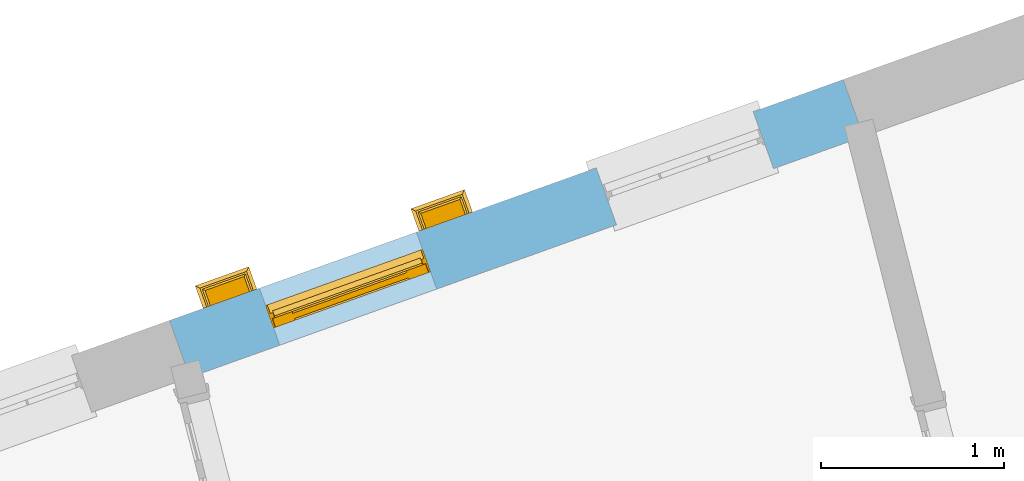
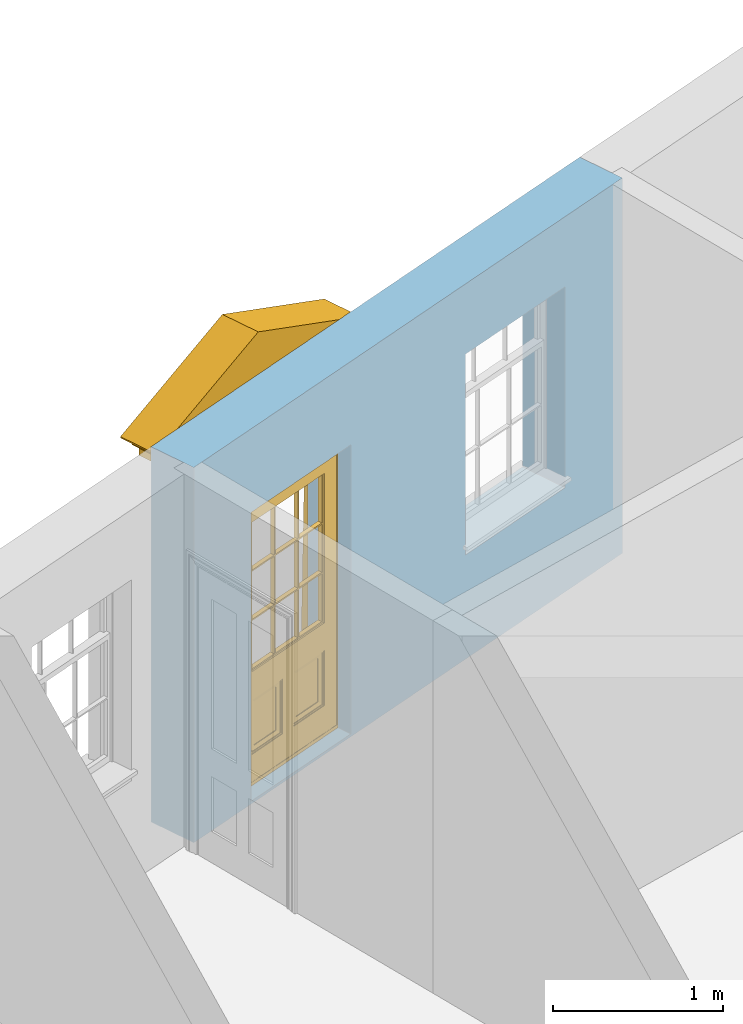
# One storey, part 12 of 15: 1 door, 2 openings, plus 1 element that does not belong to this part.
"""IFC2X3 building model written with IfcOpenShell, lengths in metres."""

from ifc_helpers import new_model, si_unit, frame, origin, place, context, subcontext, project, spatial, polyline, outline, extrude, faceted_brep, material, layer, layer_set, layer_usage, element, fill, save


model = new_model("IFC2X3")

# Units and contexts
model_context = context("Model", 3, world=origin())
body_context = subcontext(model_context, "Body", "Model", "MODEL_VIEW")
ifc_project = project(units=[si_unit("PLANEANGLEUNIT", "RADIAN"), si_unit("MASSUNIT", "GRAM", prefix="KILO"), si_unit("FORCEUNIT", "NEWTON", prefix="KILO"), si_unit("LENGTHUNIT", "METRE")], contexts=[model_context])

# Site, building, storey
site_placement = place(None, origin())
site = spatial("IfcSite", under=ifc_project, at=site_placement, CompositionType="ELEMENT")
building_placement = place(None, origin())
building = spatial("IfcBuilding", under=site, at=building_placement, Name="Building plot-13", CompositionType="ELEMENT")
storey_placement = place(None, frame((0.0, 0.0, 4.0)))
storey = spatial("IfcBuildingStorey", under=building, at=storey_placement, Name="Floor 0", CompositionType="ELEMENT", Elevation=4.0)

# Wall, openings, door
ifc_material = material(Name="Masonry")
ifc_layer = layer(ifc_material, 0.33, ventilated=False)
ifc_layer_set = layer_set([ifc_layer], Name="My Wall")
ifc_layer_usage = layer_usage(ifc_layer_set, "AXIS2", "NEGATIVE", 0.08)
wall_placement = place(storey_placement, origin())
wall = element("IfcWallStandardCase", 1, at=wall_placement, inside=storey, material=ifc_layer_usage, Name="exterior", context=body_context, shape_type="SweptSolid", body=[
    extrude(outline(polyline([(75.765136209946, 51.0653233722537), (75.6540271002417, 51.3760559996695), (71.9792289491637, 50.0620531725284), (72.090338058868, 49.7513205451126), (75.765136209946, 51.0653233722537)])), origin(), (0.0, 0.0, 1.0), 2.7),
])
opening_1_placement = place(storey_placement, frame((0.0, 0.0, 0.75)))
element("IfcOpeningElement", 2, at=opening_1_placement, cuts=wall, Name="Opening", ObjectType="Opening", context=body_context, shape_type="SweptSolid", body=[
    extrude(outline(polyline([(75.163761942697, 51.2007511865675), (74.3068931822474, 50.894359399201), (74.4180022919517, 50.5836267717852), (75.2748710524013, 50.8900185591517), (75.163761942697, 51.2007511865675)])), origin(), (0.0, 0.0, 1.0), 1.445),
])
opening_2_placement = place(storey_placement, frame((0.0, 0.0, 0.0199999999999996)))
opening_2 = element("IfcOpeningElement", 3, at=opening_2_placement, cuts=wall, Name="Opening", ObjectType="Opening", context=body_context, shape_type="SweptSolid", body=[
    extrude(outline(polyline([(73.326362867158, 50.5437497729969), (72.4694941067084, 50.2373579856305), (72.5806032164127, 49.9266253582147), (73.4374719768623, 50.2330171455811), (73.326362867158, 50.5437497729969)])), origin(), (0.0, 0.0, 1.0), 2.08),
])
door_placement = place(storey_placement, frame((73.4105364351158, 50.3083462673789, 0.0199999999999996), z_axis=(0.0, 0.0, 1.0), x_axis=(-0.856868760449572, -0.306391787366429, 0.0)))
door = element("IfcDoor", 4, at=door_placement, inside=storey, Name="house entrance", OverallHeight=2.08, OverallWidth=0.91, context=body_context, shape_type="Brep", held_by="IfcProductRepresentation", body=[
    faceted_brep([(-0.305, -0.25, 2.43), (-0.335, -0.25, 2.45), (1.245, -0.25, 2.45), (1.215, -0.25, 2.43), (-0.315, -0.25, 2.43), (-0.335, -0.25, 2.46), (1.245, -0.25, 2.46), (1.225, -0.25, 2.43), (-0.295, -0.25, 2.42), (1.205, -0.25, 2.42), (-0.315, -0.37, 2.43), (-0.305, -0.36, 2.43), (-0.335, -0.39, 2.45), (-0.335, -0.39, 2.46), (-0.395, -0.25, 2.52), (1.305, -0.25, 2.52), (1.245, -0.39, 2.46), (1.245, -0.39, 2.45), (1.225, -0.37, 2.43), (1.215, -0.36, 2.43), (-0.305, -0.25, 2.42), (1.215, -0.25, 2.42), (-0.285, -0.25, 2.41), (1.195, -0.25, 2.41), (-0.305, -0.36, 2.42), (-0.395, -0.45, 2.46), (-0.395, -0.25, 2.46), (-0.405, -0.25, 2.53), (1.315, -0.25, 2.53), (1.305, -0.25, 2.46), (1.305, -0.45, 2.46), (1.215, -0.36, 2.42), (-0.295, -0.35, 2.42), (1.205, -0.35, 2.42), (-0.285, -0.34, 2.41), (1.195, -0.34, 2.41), (-0.275, -0.25, 2.4), (1.185, -0.25, 2.4), (-0.395, -0.45, 2.52), (-0.405, -0.25, 2.52), (-0.415, -0.25, 2.54), (1.325, -0.25, 2.54), (1.315, -0.25, 2.52), (1.305, -0.45, 2.52), (-0.285, -0.25, 2.4), (-0.285, -0.34, 2.4), (1.195, -0.34, 2.4), (1.195, -0.25, 2.4), (-0.275, -0.25, 2.21), (1.185, -0.25, 2.21), (-0.405, -0.46, 2.52), (-0.405, -0.46, 2.53), (-0.415, -0.47, 2.54), (-0.425, -0.25, 2.55), (1.335, -0.25, 2.55), (1.325, -0.47, 2.54), (1.315, -0.46, 2.53), (1.315, -0.46, 2.52), (-0.275, -0.33, 2.4), (1.185, -0.33, 2.4), (-0.275, -0.33, 2.21), (1.185, -0.33, 2.21), (-0.275, -0.25, 2.2), (1.185, -0.25, 2.2), (-0.425, -0.48, 2.54), (-0.425, -0.25, 2.54), (-0.445, -0.25, 2.581), (1.355, -0.25, 2.581), (1.335, -0.25, 2.54), (1.335, -0.48, 2.54), (-0.285, -0.34, 2.21), (-0.285, -0.25, 2.21), (1.195, -0.34, 2.21), (1.195, -0.25, 2.21), (-0.285, -0.25, 2.2), (1.195, -0.25, 2.2), (-0.015, -0.25, 2.11), (0.925, -0.25, 2.11), (-0.425, -0.48, 2.55), (-0.435, -0.25, 2.556), (-0.473, -0.25, 2.591), (1.383, -0.25, 2.591), (1.345, -0.25, 2.556), (1.335, -0.48, 2.55), (-0.285, -0.34, 2.2), (1.195, -0.34, 2.2), (-0.275, -0.33, 2.2), (1.185, -0.33, 2.2), (-0.275, -0.25, 2.11), (1.185, -0.25, 2.11), (-0.015, -0.33, 2.11), (0.925, -0.33, 2.11), (-0.435, -0.49, 2.556), (-0.400858, -0.48, 2.55), (1.310858, -0.48, 2.55), (-0.445, -0.5, 2.581), (-0.473, -0.528, 2.591), (-0.473, -0.25, 2.601), (1.383, -0.25, 2.601), (1.383, -0.528, 2.591), (1.355, -0.5, 2.581), (1.345, -0.49, 2.556), (-0.275, -0.33, 2.11), (1.185, -0.33, 2.11), (-0.025, -0.25, 2.1), (-0.315, -0.25, 2.1), (1.225, -0.25, 2.1), (0.935, -0.25, 2.1), (-0.015, -0.38, 2.1), (0.925, -0.25, 2.1), (0.455, -0.48, 2.914508), (0.455, -0.49, 2.92465), (0.455, -0.48, 2.904508), (1.236538, -0.46, 2.552499), (-0.326538, -0.46, 2.552499), (0.455, -0.5, 2.953792), (0.455, -0.528, 2.975389), (-0.473, -0.528, 2.601), (0.455, -0.25, 2.985389), (1.383, -0.528, 2.601), (-0.325, -0.25, 2.11), (-0.325, -0.38, 2.11), (1.235, -0.38, 2.11), (1.235, -0.25, 2.11), (-0.015, -0.25, 2.1), (-0.035, -0.25, 2.07), (-0.305, -0.25, 2.07), (-0.325, -0.25, 2.1), (1.235, -0.25, 2.1), (0.945, -0.25, 2.07), (1.215, -0.25, 2.07), (-0.015, -0.38, 2.11), (0.925, -0.38, 2.11), (-0.38784, -0.47, 2.55125), (0.455, -0.47, 2.900365), (1.26068, -0.46, 2.552499), (1.29784, -0.47, 2.55125), (1.066733, -0.45, 2.553749), (-0.156733, -0.45, 2.553749), (-0.35068, -0.46, 2.552499), (0.455, -0.528, 2.985389), (-0.325, -0.38, 2.1), (1.235, -0.38, 2.1), (-0.025, -0.37, 2.1), (-0.025, -0.25, 2.07), (-0.305, -0.25, 2.06), (-0.035, -0.25, 2.06), (-0.315, -0.25, 2.07), (-0.315, -0.37, 2.1), (1.225, -0.37, 2.1), (0.935, -0.25, 2.07), (1.225, -0.25, 2.07), (1.215, -0.25, 2.06), (0.945, -0.25, 2.06), (0.935, -0.37, 2.1), (0.925, -0.38, 2.1), (0.455, -0.46, 2.886223), (0.455, -0.46, 2.876222), (1.022495, -0.39, 2.56125), (-0.112495, -0.39, 2.56125), (-0.31352, -0.45, 2.553749), (1.22352, -0.45, 2.553749), (-0.025, -0.37, 2.07), (-0.035, -0.36, 2.07), (-0.305, -0.36, 2.06), (-0.305, -0.36, 2.07), (-0.035, -0.36, 2.06), (-0.285, -0.25, 2.04), (-0.055, -0.25, 2.04), (-0.315, -0.37, 2.07), (1.225, -0.37, 2.07), (0.945, -0.36, 2.07), (0.935, -0.37, 2.07), (1.215, -0.36, 2.07), (1.215, -0.36, 2.06), (1.195, -0.25, 2.04), (0.965, -0.25, 2.04), (0.945, -0.36, 2.06), (0.455, -0.45, 2.872082), (1.048626, -0.39, 2.56125), (0.964197, -0.37, 2.563749), (-0.054197, -0.37, 2.563749), (-0.138626, -0.39, 2.56125), (0.455, -0.45, 2.807137), (-0.285, -0.34, 2.04), (-0.055, -0.34, 2.04), (-0.065, -0.25, 2.03), (-0.275, -0.25, 2.03), (1.195, -0.34, 2.04), (1.185, -0.25, 2.03), (0.975, -0.25, 2.03), (0.965, -0.34, 2.04), (0.455, -0.39, 2.796314), (0.455, -0.39, 2.807137), (0.455, -0.37, 2.774666), (0.935048, -0.36, 2.565), (-0.025048, -0.36, 2.565), (-0.285, -0.25, 2.03), (-0.285, -0.34, 2.03), (-0.055, -0.25, 2.03), (-0.055, -0.34, 2.03), (-0.275, -0.25, 1.94), (-0.065, -0.25, 1.94), (1.195, -0.25, 2.03), (1.195, -0.34, 2.03), (1.185, -0.25, 1.94), (0.975, -0.25, 1.94), (0.965, -0.25, 2.03), (0.965, -0.34, 2.03), (0.455, -0.36, 2.774666), (0.961179, -0.36, 2.565), (0.87675, -0.34, 2.567501), (0.03325, -0.34, 2.567501), (-0.051179, -0.36, 2.565), (-0.275, -0.33, 2.03), (-0.065, -0.33, 2.03), (-0.275, -0.33, 1.94), (-0.065, -0.33, 1.94), (-0.275, -0.25, 1.93), (-0.065, -0.25, 1.93), (1.185, -0.33, 2.03), (1.185, -0.33, 1.94), (1.185, -0.25, 1.93), (0.975, -0.25, 1.93), (0.975, -0.33, 1.94), (0.975, -0.33, 2.03), (0.455, -0.36, 2.763843), (0.902881, -0.34, 2.567501), (0.93203, -0.35, 2.566251), (0.036268, -0.33, 2.568751), (0.873732, -0.33, 2.568751), (-0.02203, -0.35, 2.566251), (0.007119, -0.34, 2.567501), (-0.285, -0.25, 1.94), (-0.285, -0.34, 1.94), (-0.055, -0.34, 1.94), (-0.055, -0.25, 1.94), (-0.285, -0.25, 1.93), (-0.055, -0.25, 1.93), (-0.295, -0.25, 0.13), (-0.045, -0.25, 0.13), (1.195, -0.34, 1.94), (1.195, -0.25, 1.94), (1.195, -0.25, 1.93), (1.205, -0.25, 0.13), (0.955, -0.25, 0.13), (0.965, -0.25, 1.94), (0.965, -0.25, 1.93), (0.965, -0.34, 1.94), (0.455, -0.35, 2.763843), (0.455, -0.34, 2.742194), (0.455, -0.34, 2.753017), (0.455, -0.33, 2.742194), (-0.285, -0.34, 1.93), (-0.055, -0.34, 1.93), (-0.275, -0.33, 1.93), (-0.065, -0.33, 1.93), (-0.295, -0.35, 0.13), (-0.045, -0.35, 0.13), (-0.305, -0.25, 0.12), (-0.035, -0.25, 0.12), (1.195, -0.34, 1.93), (1.185, -0.33, 1.93), (1.205, -0.35, 0.13), (1.215, -0.25, 0.12), (0.945, -0.25, 0.12), (0.955, -0.35, 0.13), (0.975, -0.33, 1.93), (0.965, -0.34, 1.93), (-0.305, -0.25, 0.13), (-0.305, -0.36, 0.13), (-0.035, -0.25, 0.13), (-0.035, -0.36, 0.13), (-0.325, -0.25, 0.1), (-0.015, -0.25, 0.1), (1.215, -0.36, 0.13), (1.215, -0.25, 0.13), (1.235, -0.25, 0.1), (0.925, -0.25, 0.1), (0.945, -0.25, 0.13), (0.945, -0.36, 0.13), (-0.305, -0.36, 0.12), (-0.035, -0.36, 0.12), (-0.325, -0.38, 0.1), (-0.015, -0.38, 0.1), (-0.325, -0.25, 0.08), (-0.015, -0.25, 0.08), (1.215, -0.36, 0.12), (1.235, -0.38, 0.1), (1.235, -0.25, 0.08), (0.925, -0.25, 0.08), (0.925, -0.38, 0.1), (0.945, -0.36, 0.12), (-0.325, -0.38, 0.08), (-0.015, -0.38, 0.08), (-0.315, -0.25, 0.07), (-0.025, -0.25, 0.07), (1.235, -0.38, 0.08), (1.225, -0.25, 0.07), (0.935, -0.25, 0.07), (0.925, -0.38, 0.08), (-0.315, -0.37, 0.07), (-0.025, -0.37, 0.07), (-0.015, -0.25, 0.0), (-0.325, -0.25, 0.0), (1.225, -0.37, 0.07), (1.235, -0.25, 0.0), (0.925, -0.25, 0.0), (0.935, -0.37, 0.07), (-0.325, -0.25, 0.07), (-0.325, -0.38, 0.07), (-0.015, -0.38, 0.07), (-0.015, -0.25, 0.07), (-0.015, -0.38, 0.0), (-0.325, -0.38, 0.0), (1.235, -0.38, 0.07), (1.235, -0.25, 0.07), (1.235, -0.38, 0.0), (0.925, -0.38, 0.0), (0.925, -0.25, 0.07), (0.925, -0.38, 0.07), (0.885, -0.072, 0.025), (0.025, -0.072, 0.025), (0.025, -0.1, 0.025), (0.885, -0.1, 0.025), (0.9, -0.02, 0.025), (0.01, -0.02, 0.025), (0.9, -0.072, 0.025), (0.91, -0.02, 0.0), (0.0, -0.02, 0.0), (0.01, -0.072, 0.025), (0.9, -0.072, 2.07), (0.9, -0.02, 2.07), (0.885, -0.072, 2.055), (0.91, -0.02, 2.08), (0.01, -0.02, 2.07), (0.0, -0.02, 2.08), (0.01, -0.072, 2.07), (0.025, -0.072, 2.055), (0.0, -0.15, 0.0), (0.0, -0.15, 2.08), (0.91, -0.15, 0.0), (0.01, -0.15, 0.025), (0.01, -0.15, 2.07), (0.9, -0.15, 0.025), (0.91, -0.15, 2.08), (0.01, -0.1, 0.025), (0.01, -0.1, 2.065), (0.9, -0.15, 2.07), (0.025, -0.1, 2.055), (0.9, -0.1, 2.065), (0.9, -0.1, 0.025), (0.885, -0.1, 2.055), (0.898, -0.07, 2.068), (0.898, -0.02, 2.068), (0.012, -0.02, 2.068), (0.012, -0.07, 2.068), (0.898, -0.07, 0.075), (0.898, -0.02, 0.027), (0.012, -0.02, 0.027), (0.012, -0.07, 0.075), (0.898, -0.07, 0.027), (0.012, -0.07, 0.027), (0.883, -0.07, 0.027), (0.883, -0.07, 0.075), (0.027, -0.07, 0.027), (0.027, -0.07, 0.075), (0.883, -0.08, 0.075), (0.883, -0.11, 0.045), (0.027, -0.11, 0.045), (0.027, -0.08, 0.075), (0.027, -0.11, 0.027), (0.883, -0.11, 0.027), (0.745, -0.05, 0.265), (0.545, -0.05, 0.265), (0.545, -0.055, 0.265), (0.745, -0.055, 0.265), (0.745, -0.05, 0.58), (0.545, -0.05, 0.58), (0.545, -0.055, 0.58), (0.515, -0.06, 0.235), (0.775, -0.06, 0.235), (0.745, -0.055, 0.58), (0.515, -0.06, 0.61), (0.515, -0.065, 0.235), (0.775, -0.065, 0.235), (0.775, -0.06, 0.61), (0.515, -0.065, 0.61), (0.785, -0.065, 0.225), (0.505, -0.065, 0.225), (0.775, -0.065, 0.61), (0.505, -0.065, 0.62), (0.785, -0.065, 0.62), (0.505, -0.07, 0.225), (0.785, -0.07, 0.225), (0.505, -0.07, 0.62), (0.785, -0.07, 0.62), (0.405, -0.07, 0.62), (0.405, -0.07, 0.225), (0.785, -0.07, 0.82), (0.125, -0.07, 0.82), (0.405, -0.065, 0.62), (0.405, -0.065, 0.225), (0.125, -0.07, 0.225), (0.785, -0.06, 0.82), (0.125, -0.06, 0.82), (0.125, -0.07, 0.62), (0.125, -0.065, 0.62), (0.395, -0.065, 0.61), (0.395, -0.065, 0.235), (0.125, -0.065, 0.225), (0.785, -0.07, 1.895), (0.558333, -0.06, 0.83), (0.351667, -0.06, 0.83), (0.125, -0.07, 1.895), (0.125, -0.06, 1.895), (0.785, -0.06, 1.895), (0.135, -0.065, 0.61), (0.395, -0.06, 0.61), (0.395, -0.06, 0.235), (0.135, -0.065, 0.235), (0.568333, -0.06, 0.83), (0.558333, -0.03, 0.83), (0.351667, -0.03, 0.83), (0.341667, -0.06, 0.83), (0.135, -0.06, 1.185), (0.135, -0.06, 1.53), (0.775, -0.06, 1.53), (0.775, -0.06, 1.185), (0.135, -0.06, 0.61), (0.365, -0.055, 0.58), (0.365, -0.055, 0.265), (0.135, -0.06, 0.235), (0.568333, -0.06, 1.175), (0.558333, -0.06, 1.175), (0.775, -0.06, 0.83), (0.558333, -0.03, 1.175), (0.785, -0.03, 0.82), (0.125, -0.03, 0.82), (0.351667, -0.03, 1.175), (0.351667, -0.06, 1.175), (0.341667, -0.06, 1.175), (0.135, -0.06, 0.83), (0.135, -0.06, 1.175), (0.135, -0.03, 1.185), (0.135, -0.03, 1.53), (0.135, -0.06, 1.54), (0.351667, -0.06, 1.885), (0.558333, -0.06, 1.885), (0.775, -0.03, 1.53), (0.775, -0.03, 1.185), (0.775, -0.06, 1.175), (0.775, -0.06, 1.54), (0.165, -0.055, 0.58), (0.365, -0.05, 0.58), (0.365, -0.05, 0.265), (0.165, -0.055, 0.265), (0.568333, -0.03, 0.83), (0.568333, -0.03, 1.175), (0.568333, -0.06, 1.185), (0.558333, -0.06, 1.185), (0.775, -0.03, 0.83), (0.785, -0.02, 0.82), (0.125, -0.02, 0.82), (0.341667, -0.03, 0.83), (0.341667, -0.03, 1.175), (0.351667, -0.06, 1.185), (0.341667, -0.06, 1.185), (0.135, -0.03, 0.83), (0.341667, -0.03, 1.185), (0.125, -0.03, 1.895), (0.341667, -0.03, 1.53), (0.341667, -0.06, 1.53), (0.135, -0.06, 1.885), (0.341667, -0.06, 1.54), (0.341667, -0.06, 1.885), (0.558333, -0.03, 1.885), (0.351667, -0.03, 1.885), (0.568333, -0.06, 1.885), (0.785, -0.03, 1.895), (0.568333, -0.03, 1.185), (0.568333, -0.06, 1.53), (0.568333, -0.03, 1.53), (0.568333, -0.06, 1.54), (0.775, -0.06, 1.885), (0.165, -0.05, 0.58), (0.165, -0.05, 0.265), (0.775, -0.03, 1.175), (0.558333, -0.06, 1.53), (0.351667, -0.03, 1.185), (0.558333, -0.03, 1.185), (0.505, -0.02, 0.62), (0.405, -0.02, 0.62), (0.125, -0.02, 1.895), (0.785, -0.02, 1.895), (0.351667, -0.06, 1.53), (0.135, -0.03, 1.175), (0.135, -0.03, 1.54), (0.341667, -0.03, 1.54), (0.135, -0.03, 1.885), (0.351667, -0.06, 1.54), (0.558333, -0.03, 1.54), (0.558333, -0.06, 1.54), (0.351667, -0.03, 1.54), (0.775, -0.03, 1.54), (0.568333, -0.03, 1.54), (0.775, -0.03, 1.885), (0.558333, -0.03, 1.53), (0.405, -0.02, 0.225), (0.505, -0.02, 0.225), (0.125, -0.02, 0.62), (0.785, -0.02, 0.62), (0.351667, -0.03, 1.53), (0.341667, -0.03, 1.885), (0.568333, -0.03, 1.885), (0.405, -0.025, 0.225), (0.405, -0.025, 0.62), (0.505, -0.025, 0.62), (0.505, -0.025, 0.225), (0.125, -0.025, 0.62), (0.785, -0.025, 0.62), (0.395, -0.025, 0.235), (0.395, -0.025, 0.61), (0.125, -0.02, 0.225), (0.125, -0.025, 0.225), (0.515, -0.025, 0.61), (0.515, -0.025, 0.235), (0.785, -0.02, 0.225), (0.785, -0.025, 0.225), (0.135, -0.025, 0.61), (0.775, -0.025, 0.61), (0.135, -0.025, 0.235), (0.395, -0.03, 0.235), (0.395, -0.03, 0.61), (0.515, -0.03, 0.61), (0.515, -0.03, 0.235), (0.775, -0.025, 0.235), (0.135, -0.03, 0.61), (0.775, -0.03, 0.61), (0.135, -0.03, 0.235), (0.365, -0.035, 0.265), (0.365, -0.035, 0.58), (0.545, -0.035, 0.58), (0.545, -0.035, 0.265), (0.775, -0.03, 0.235), (0.165, -0.035, 0.58), (0.745, -0.035, 0.58), (0.165, -0.035, 0.265), (0.365, -0.04, 0.58), (0.365, -0.04, 0.265), (0.545, -0.04, 0.58), (0.545, -0.04, 0.265), (0.745, -0.035, 0.265), (0.165, -0.04, 0.58), (0.745, -0.04, 0.58), (0.165, -0.04, 0.265), (0.745, -0.04, 0.265)], [[[0, 1, 2, 3]], [[0, 4, 1]], [[1, 5, 6, 2]], [[7, 3, 2]], [[8, 0, 3, 9]], [[10, 4, 0, 11]], [[12, 1, 4, 10]], [[1, 12, 13, 5]], [[5, 14, 15, 6]], [[6, 16, 17, 2]], [[7, 18, 19, 3]], [[2, 17, 18, 7]], [[8, 20, 0]], [[21, 9, 3]], [[22, 8, 9, 23]], [[11, 0, 20, 24]], [[10, 11, 19, 18]], [[12, 10, 18, 17]], [[25, 26, 5, 13]], [[13, 12, 17, 16]], [[5, 26, 14]], [[14, 27, 28, 15]], [[29, 6, 15]], [[29, 30, 16, 6]], [[3, 19, 31, 21]], [[24, 20, 8, 32]], [[21, 31, 33, 9]], [[32, 8, 22, 34]], [[9, 33, 35, 23]], [[36, 22, 23, 37]], [[11, 24, 31, 19]], [[38, 14, 26, 25]], [[25, 13, 16, 30]], [[14, 39, 27]], [[27, 40, 41, 28]], [[42, 15, 28]], [[15, 43, 30, 29]], [[24, 32, 33, 31]], [[34, 22, 44, 45]], [[32, 34, 35, 33]], [[23, 35, 46, 47]], [[36, 44, 22]], [[47, 37, 23]], [[48, 36, 37, 49]], [[50, 39, 14, 38]], [[38, 25, 30, 43]], [[51, 27, 39, 50]], [[52, 40, 27, 51]], [[40, 53, 54, 41]], [[41, 55, 56, 28]], [[42, 57, 43, 15]], [[28, 56, 57, 42]], [[45, 44, 36, 58]], [[34, 45, 46, 35]], [[47, 46, 59, 37]], [[60, 58, 36, 48]], [[59, 61, 49, 37]], [[62, 48, 49, 63]], [[50, 38, 43, 57]], [[51, 50, 57, 56]], [[64, 65, 40, 52]], [[52, 51, 56, 55]], [[40, 65, 53]], [[53, 66, 67, 54]], [[68, 41, 54]], [[68, 69, 55, 41]], [[45, 58, 59, 46]], [[58, 60, 61, 59]], [[70, 60, 48, 71]], [[61, 72, 73, 49]], [[71, 48, 62, 74]], [[49, 73, 75, 63]], [[76, 62, 63, 77]], [[78, 53, 65, 64]], [[64, 52, 55, 69]], [[53, 79, 66]], [[66, 80, 81, 67]], [[82, 54, 67]], [[54, 83, 69, 68]], [[60, 70, 72, 61]], [[84, 70, 71, 74]], [[72, 85, 75, 73]], [[86, 84, 74, 62]], [[85, 87, 63, 75]], [[76, 88, 62]], [[89, 77, 63]], [[90, 76, 77, 91]], [[92, 79, 53, 78]], [[78, 64, 93]], [[64, 69, 94, 93]], [[95, 66, 79, 92]], [[80, 66, 95, 96]], [[80, 97, 98, 81]], [[99, 100, 67, 81]], [[82, 101, 83, 54]], [[67, 100, 101, 82]], [[83, 94, 69]], [[70, 84, 85, 72]], [[84, 86, 87, 85]], [[102, 86, 62, 88]], [[87, 103, 89, 63]], [[88, 76, 104, 105]], [[77, 89, 106, 107]], [[76, 90, 108]], [[91, 77, 109]], [[86, 90, 91, 87]], [[78, 110, 111, 92]], [[110, 78, 93, 112]], [[93, 94, 113, 114]], [[92, 111, 115, 95]], [[95, 115, 116, 96]], [[117, 97, 80, 96]], [[118, 98, 97]], [[98, 119, 99, 81]], [[116, 115, 100, 99]], [[101, 111, 110, 83]], [[100, 115, 111, 101]], [[112, 94, 83, 110]], [[86, 102, 90]], [[102, 88, 120, 121]], [[103, 87, 91]], [[89, 103, 122, 123]], [[76, 124, 104]], [[104, 125, 126, 105]], [[120, 88, 105, 127]], [[89, 123, 128, 106]], [[129, 107, 106, 130]], [[109, 77, 107]], [[90, 131, 108]], [[108, 124, 76]], [[109, 132, 91]], [[112, 93, 133, 134]], [[135, 113, 94, 136]], [[137, 138, 114, 113]], [[133, 93, 114, 139]], [[116, 140, 117, 96]], [[118, 97, 117, 140]], [[98, 118, 140, 119]], [[140, 116, 99, 119]], [[134, 136, 94, 112]], [[121, 131, 90, 102]], [[120, 127, 141, 121]], [[132, 122, 103, 91]], [[128, 123, 122, 142]], [[104, 124, 108, 143]], [[104, 144, 125]], [[145, 126, 125, 146]], [[105, 126, 147]], [[127, 105, 148, 141]], [[106, 128, 142, 149]], [[129, 150, 107]], [[106, 151, 130]], [[130, 152, 153, 129]], [[109, 107, 154, 155]], [[108, 131, 121, 141]], [[109, 155, 132]], [[134, 133, 139, 156]], [[157, 113, 135, 156]], [[156, 135, 136, 134]], [[137, 158, 159, 138]], [[160, 114, 138]], [[161, 137, 113]], [[156, 139, 114, 157]], [[132, 155, 142, 122]], [[148, 143, 108, 141]], [[144, 104, 143, 162]], [[125, 144, 162, 163]], [[126, 145, 164, 165]], [[146, 125, 163, 166]], [[167, 145, 146, 168]], [[147, 126, 165, 169]], [[105, 147, 169, 148]], [[154, 149, 142, 155]], [[151, 106, 149, 170]], [[150, 129, 171, 172]], [[107, 150, 172, 154]], [[130, 151, 170, 173]], [[152, 130, 173, 174]], [[152, 175, 176, 153]], [[129, 153, 177, 171]], [[178, 161, 113, 157]], [[179, 158, 137]], [[158, 180, 181, 159]], [[182, 138, 159]], [[157, 114, 160, 178]], [[178, 160, 138, 183]], [[183, 137, 161, 178]], [[162, 143, 148, 169]], [[165, 163, 162, 169]], [[145, 167, 184, 164]], [[166, 163, 165, 164]], [[168, 146, 166, 185]], [[186, 187, 167, 168]], [[154, 172, 170, 149]], [[171, 173, 170, 172]], [[171, 177, 174, 173]], [[175, 152, 174, 188]], [[189, 190, 176, 175]], [[153, 176, 191, 177]], [[192, 158, 179, 193]], [[193, 179, 137, 183]], [[194, 180, 158, 192]], [[180, 195, 196, 181]], [[192, 159, 181, 194]], [[183, 138, 182, 193]], [[193, 182, 159, 192]], [[167, 197, 198, 184]], [[164, 184, 185, 166]], [[199, 168, 185, 200]], [[201, 187, 186, 202]], [[187, 197, 167]], [[168, 199, 186]], [[188, 174, 177, 191]], [[203, 175, 188, 204]], [[189, 205, 206, 190]], [[207, 176, 190]], [[203, 189, 175]], [[176, 207, 208, 191]], [[209, 210, 180, 194]], [[210, 195, 180]], [[195, 211, 212, 196]], [[213, 181, 196]], [[194, 181, 213, 209]], [[214, 198, 197, 187]], [[185, 184, 198, 200]], [[199, 200, 215, 186]], [[187, 201, 216, 214]], [[202, 186, 215, 217]], [[218, 201, 202, 219]], [[188, 191, 208, 204]], [[204, 220, 189, 203]], [[205, 189, 220, 221]], [[205, 222, 223, 206]], [[190, 206, 224, 225]], [[208, 207, 190, 225]], [[226, 195, 210, 209]], [[227, 211, 195, 228]], [[229, 212, 211, 230]], [[231, 196, 212, 232]], [[209, 213, 196, 226]], [[214, 215, 200, 198]], [[233, 234, 216, 201]], [[214, 216, 217, 215]], [[217, 235, 236, 202]], [[218, 237, 233, 201]], [[202, 236, 238, 219]], [[239, 218, 219, 240]], [[225, 220, 204, 208]], [[221, 220, 225, 224]], [[241, 242, 205, 221]], [[243, 222, 205, 242]], [[222, 244, 245, 223]], [[246, 206, 223, 247]], [[248, 224, 206, 246]], [[249, 228, 195, 226]], [[250, 211, 227, 251]], [[251, 227, 228, 249]], [[250, 212, 229, 252]], [[252, 230, 211, 250]], [[252, 229, 230]], [[226, 196, 231, 249]], [[251, 232, 212, 250]], [[249, 231, 232, 251]], [[237, 253, 234, 233]], [[217, 216, 234, 235]], [[238, 236, 235, 254]], [[255, 253, 237, 218]], [[238, 254, 256, 219]], [[218, 239, 257, 255]], [[240, 219, 256, 258]], [[259, 239, 240, 260]], [[221, 224, 248, 241]], [[261, 243, 242, 241]], [[261, 262, 222, 243]], [[262, 263, 244, 222]], [[244, 264, 265, 245]], [[223, 245, 266, 267]], [[268, 247, 223, 267]], [[246, 247, 268, 248]], [[253, 254, 235, 234]], [[255, 256, 254, 253]], [[239, 269, 270, 257]], [[255, 257, 258, 256]], [[271, 240, 258, 272]], [[259, 269, 239]], [[240, 271, 260]], [[273, 259, 260, 274]], [[268, 261, 241, 248]], [[267, 262, 261, 268]], [[263, 262, 267, 266]], [[263, 275, 276, 244]], [[276, 264, 244]], [[264, 277, 278, 265]], [[279, 245, 265]], [[245, 279, 280, 266]], [[269, 259, 281, 270]], [[272, 258, 257, 270]], [[260, 271, 272, 282]], [[259, 273, 283, 281]], [[274, 260, 282, 284]], [[285, 273, 274, 286]], [[275, 263, 266, 280]], [[264, 276, 275, 287]], [[277, 264, 287, 288]], [[277, 289, 290, 278]], [[265, 278, 291, 292]], [[279, 265, 292, 280]], [[282, 272, 270, 281]], [[285, 293, 283, 273]], [[284, 282, 281, 283]], [[286, 274, 284, 294]], [[295, 285, 286, 296]], [[280, 292, 287, 275]], [[292, 291, 288, 287]], [[297, 289, 277, 288]], [[289, 298, 299, 290]], [[278, 290, 300, 291]], [[285, 295, 301, 293]], [[294, 284, 283, 293]], [[296, 286, 294, 302]], [[303, 304, 295, 296]], [[291, 300, 297, 288]], [[298, 289, 297, 305]], [[306, 307, 299, 298]], [[290, 299, 308, 300]], [[309, 310, 301, 295]], [[293, 301, 302, 294]], [[302, 311, 312, 296]], [[313, 314, 304, 303]], [[304, 309, 295]], [[296, 312, 303]], [[305, 297, 300, 308]], [[315, 316, 298, 305]], [[317, 318, 307, 306]], [[319, 299, 307]], [[316, 306, 298]], [[320, 308, 299, 319]], [[309, 304, 314, 310]], [[302, 301, 310, 311]], [[303, 312, 311, 313]], [[310, 314, 313, 311]], [[305, 308, 320, 315]], [[306, 316, 315, 317]], [[317, 315, 320, 318]], [[319, 307, 318, 320]], [[321, 322, 323, 324]], [[322, 321, 325, 326]], [[327, 325, 321]], [[325, 328, 329, 326]], [[330, 322, 326]], [[331, 332, 325, 327]], [[327, 321, 333, 331]], [[332, 334, 328, 325]], [[335, 326, 329, 336]], [[337, 338, 322, 330]], [[326, 335, 337, 330]], [[332, 335, 336, 334]], [[331, 337, 335, 332]], [[336, 329, 339, 340]], [[341, 339, 329, 328]], [[339, 342, 343, 340]], [[339, 341, 344, 342]], [[345, 341, 328, 334]], [[346, 347, 343, 342]], [[348, 344, 341, 345]], [[342, 344, 324, 323]], [[323, 349, 347, 346]], [[346, 342, 323]], [[344, 348, 350, 351]], [[351, 324, 344]], [[338, 349, 323, 322]], [[351, 350, 352, 324]], [[333, 338, 337, 331]], [[333, 321, 324, 352]], [[340, 345, 334, 336]], [[338, 333, 352, 349]], [[353, 354, 355, 356]], [[357, 358, 354, 353]], [[359, 360, 356, 355]], [[361, 358, 357]], [[359, 362, 360]], [[358, 361, 363]], [[364, 363, 361, 357]], [[362, 359, 365]], [[360, 362, 365, 366]], [[359, 358, 363, 365]], [[367, 368, 363, 364]], [[366, 365, 369, 370]], [[371, 365, 363, 372]], [[372, 363, 368]], [[371, 369, 365]], [[373, 374, 375, 376]], [[373, 377, 378, 374]], [[378, 379, 375, 374]], [[376, 375, 380, 381]], [[382, 377, 373, 376]], [[382, 379, 378, 377]], [[375, 379, 383, 380]], [[381, 380, 384, 385]], [[381, 386, 382, 376]], [[386, 383, 379, 382]], [[380, 383, 387, 384]], [[388, 385, 384, 389]], [[385, 390, 386, 381]], [[390, 387, 383, 386]], [[391, 389, 384, 387]], [[388, 392, 390, 385]], [[388, 389, 393, 394]], [[387, 390, 392, 391]], [[389, 391, 395, 393]], [[394, 396, 392, 388]], [[364, 357, 394, 393]], [[396, 395, 391, 392]], [[393, 395, 397, 398]], [[396, 394, 357]], [[366, 364, 393, 398]], [[395, 396, 399]], [[399, 400, 397, 395]], [[398, 397, 401, 402]], [[396, 357, 353, 399]], [[370, 367, 364, 366]], [[366, 398, 403, 360]], [[404, 405, 400, 399]], [[397, 400, 406]], [[397, 406, 407, 401]], [[408, 409, 402, 401]], [[402, 410, 403, 398]], [[353, 411, 399]], [[369, 368, 367, 370]], [[403, 406, 360]], [[405, 404, 412, 413]], [[414, 400, 405, 415]], [[399, 411, 416, 404]], [[356, 360, 406, 400]], [[410, 407, 406, 403]], [[401, 407, 417, 408]], [[409, 408, 418, 419]], [[420, 410, 402, 409]], [[414, 411, 353, 356]], [[368, 369, 371, 372]], [[421, 412, 404]], [[413, 412, 422, 423]], [[413, 424, 405]], [[414, 356, 400]], [[415, 405, 425, 426]], [[411, 414, 415, 416]], [[427, 428, 404, 416]], [[420, 417, 407, 410]], [[408, 417, 429, 418]], [[419, 418, 430, 431]], [[419, 432, 420, 409]], [[421, 433, 434, 412]], [[421, 404, 435]], [[412, 434, 436, 422]], [[437, 438, 423, 422]], [[423, 439, 440, 413]], [[413, 440, 441, 424]], [[424, 442, 405]], [[443, 425, 405]], [[426, 425, 444, 445]], [[446, 415, 426]], [[416, 415, 447, 448]], [[449, 450, 428, 427]], [[451, 404, 428]], [[452, 427, 416]], [[432, 429, 417, 420]], [[418, 429, 453, 430]], [[430, 454, 455, 431]], [[431, 456, 432, 419]], [[457, 458, 433, 421]], [[434, 433, 459, 460]], [[435, 404, 451]], [[461, 457, 421, 435]], [[436, 434, 440, 439]], [[422, 436, 458, 457]], [[462, 463, 438, 437]], [[438, 464, 423]], [[457, 437, 422]], [[464, 465, 439, 423]], [[441, 440, 466, 467]], [[424, 441, 465, 464]], [[442, 424, 464, 468]], [[442, 443, 405]], [[467, 425, 443, 441]], [[467, 469, 444, 425]], [[445, 444, 438, 470]], [[471, 472, 426, 445]], [[473, 415, 446]], [[474, 446, 426, 472]], [[475, 447, 415]], [[476, 448, 447, 477]], [[478, 416, 448]], [[479, 437, 450, 449]], [[480, 459, 428, 450]], [[481, 482, 449, 427]], [[428, 459, 433, 451]], [[452, 483, 481, 427]], [[452, 416, 484]], [[456, 453, 429, 432]], [[430, 453, 485, 454]], [[455, 454, 485, 486]], [[455, 486, 456, 431]], [[433, 458, 487, 451]], [[488, 460, 459, 481]], [[460, 466, 440, 434]], [[435, 451, 487, 461]], [[457, 461, 437]], [[489, 490, 436, 439]], [[458, 436, 490, 480]], [[491, 492, 463, 462]], [[470, 438, 463, 493]], [[494, 462, 437, 479]], [[438, 468, 464]], [[439, 465, 469, 489]], [[472, 467, 466, 495]], [[465, 441, 443, 496]], [[468, 496, 443, 442]], [[471, 469, 467, 472]], [[465, 496, 444, 469]], [[444, 496, 438]], [[497, 445, 470]], [[471, 445, 497, 498]], [[475, 415, 473]], [[446, 497, 499, 473]], [[474, 498, 497, 446]], [[472, 495, 500, 474]], [[447, 475, 474, 500]], [[501, 502, 448, 476]], [[500, 503, 477, 447]], [[470, 479, 476, 477]], [[478, 484, 416]], [[478, 448, 502, 483]], [[487, 450, 437]], [[504, 479, 449]], [[481, 459, 480, 482]], [[480, 450, 487, 458]], [[505, 504, 449, 482]], [[505, 483, 452, 504]], [[488, 481, 483, 502]], [[504, 452, 484, 506]], [[485, 453, 456, 486]], [[507, 490, 460, 488]], [[460, 490, 489, 466]], [[461, 487, 437]], [[482, 480, 490, 507]], [[508, 492, 491, 509]], [[492, 510, 463]], [[491, 462, 511]], [[463, 355, 493]], [[479, 470, 493, 494]], [[462, 494, 354]], [[468, 438, 496]], [[512, 489, 469, 471]], [[495, 466, 489, 512]], [[470, 499, 497]], [[512, 471, 498, 503]], [[513, 475, 473, 499]], [[498, 474, 475, 513]], [[502, 500, 495, 488]], [[502, 501, 503, 500]], [[505, 501, 476, 514]], [[503, 498, 513, 477]], [[514, 476, 479]], [[477, 513, 470]], [[478, 514, 506, 484]], [[483, 505, 514, 478]], [[504, 506, 479]], [[482, 507, 501, 505]], [[507, 488, 495, 512]], [[515, 516, 492, 508]], [[509, 491, 517, 518]], [[509, 358, 359, 508]], [[516, 519, 510, 492]], [[359, 355, 463, 510]], [[462, 354, 358, 511]], [[520, 517, 491, 511]], [[355, 354, 494, 493]], [[513, 499, 470]], [[503, 501, 507, 512]], [[506, 514, 479]], [[516, 515, 521, 522]], [[508, 523, 524, 515]], [[525, 526, 518, 517]], [[527, 509, 518, 528]], [[509, 527, 358]], [[523, 508, 359]], [[529, 519, 516, 522]], [[523, 510, 519, 524]], [[523, 359, 510]], [[511, 358, 527]], [[520, 530, 525, 517]], [[528, 520, 511, 527]], [[531, 521, 515, 524]], [[532, 533, 522, 521]], [[526, 525, 534, 535]], [[528, 518, 526, 536]], [[524, 519, 529, 531]], [[533, 537, 529, 522]], [[536, 530, 520, 528]], [[538, 534, 525, 530]], [[521, 531, 539, 532]], [[540, 541, 533, 532]], [[535, 534, 542, 543]], [[536, 526, 535, 544]], [[531, 529, 537, 539]], [[541, 545, 537, 533]], [[544, 538, 530, 536]], [[546, 542, 534, 538]], [[532, 539, 547, 540]], [[548, 541, 540, 549]], [[542, 550, 551, 543]], [[544, 535, 543, 552]], [[539, 537, 545, 547]], [[548, 553, 545, 541]], [[552, 546, 538, 544]], [[554, 550, 542, 546]], [[540, 547, 555, 549]], [[555, 553, 548, 549]], [[551, 550, 554, 556]], [[552, 543, 551, 556]], [[545, 553, 555, 547]], [[554, 546, 552, 556]], [[340, 343, 348, 345]], [[343, 347, 350, 348]], [[349, 352, 350, 347]]]),
])
fill(opening_2, door)

save(model, "model.ifc")
